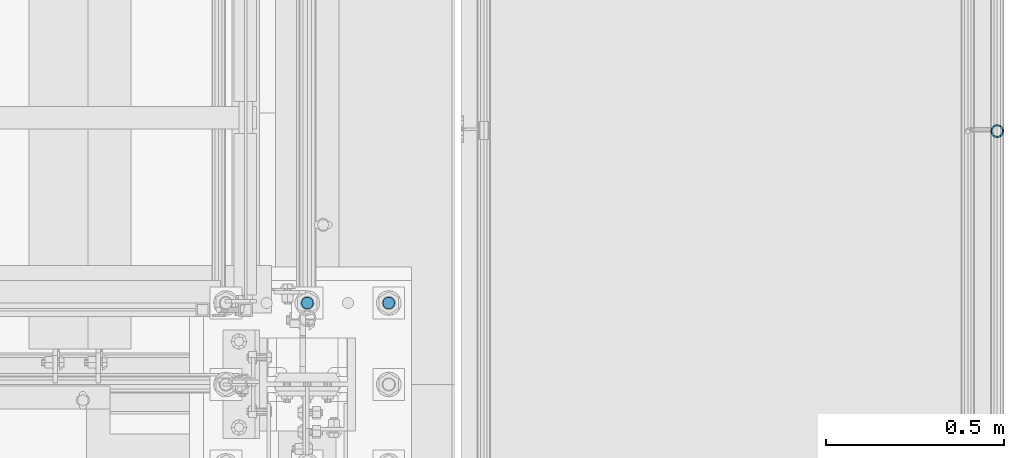
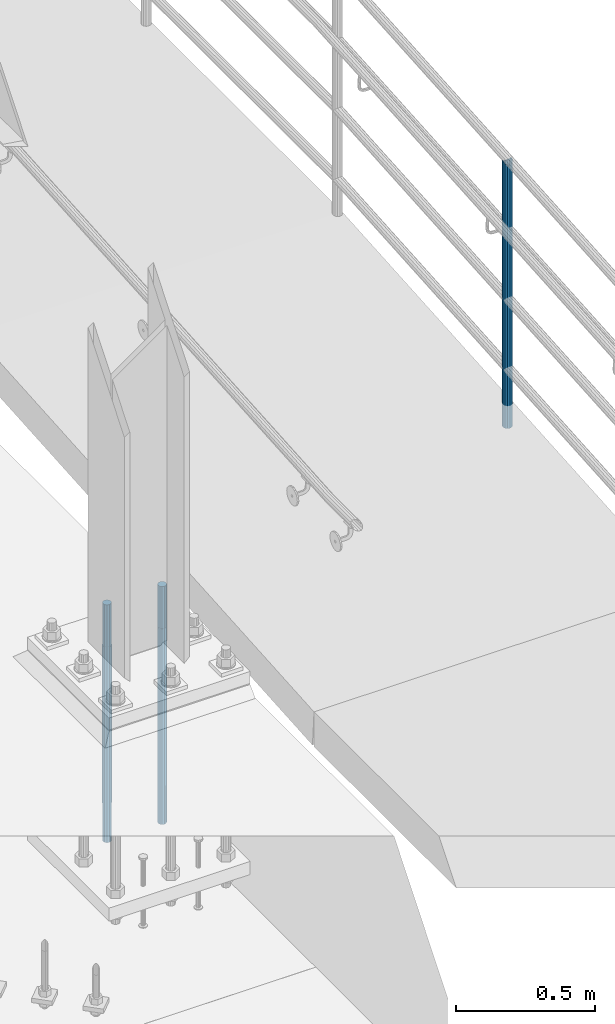
# One storey, part 658 of 1876: 3 columns, 2 elements without a shape of their own.
"""IFC2X3 building model written with IfcOpenShell, lengths in millimetres."""

import ifcopenshell
import ifcopenshell.guid

model = None  # the IFC model being written
_history = None  # IfcOwnerHistory: only IFC2X3 demands one
_inside = {}  # id of a spatial element -> (the spatial element, [elements in it])
_under = {}  # id of a project, library or spatial element -> (it, [spatial elements below it])
_declared = {}  # id of a project -> (the project, [libraries it declares])
_typed = {}  # id of a type object -> (the type object, [elements of that type])
_made_of = {}  # id of a material, layer set ... -> (it, [elements and type objects made of it])


def new_model(schema):
    """Start an empty IFC model of exactly this schema.

    Asked for "IFC4X3", IfcOpenShell would pick the latest addendum, in which some entities
    have other attributes; the version numbers below select the first issue.
    IFC2X3 requires an IfcOwnerHistory on every rooted entity: one is made here for all.
    """
    global model, _history
    if schema == "IFC4X3":
        model = ifcopenshell.file(schema_version=(4, 3, 0, 0))
    else:
        model = ifcopenshell.file(schema=schema)
    _inside.clear()
    _under.clear()
    _declared.clear()
    _typed.clear()
    _made_of.clear()
    _history = None
    if model.schema == "IFC2X3":
        org = make("IfcOrganization", Name="unknown")
        user = make(
            "IfcPersonAndOrganization",
            ThePerson=make("IfcPerson", FamilyName="unknown"),
            TheOrganization=org,
        )
        app = make(
            "IfcApplication",
            ApplicationDeveloper=org,
            Version="unknown",
            ApplicationFullName="unknown",
            ApplicationIdentifier="unknown",
        )
        _history = make(
            "IfcOwnerHistory",
            OwningUser=user,
            OwningApplication=app,
            ChangeAction="ADDED",
            CreationDate=0,
        )
    return model


def make(cls, **values):
    """One entity of the class cls with the attributes given. An attribute that is None is left unset."""
    return model.create_entity(
        cls, **{name: value for name, value in values.items() if value is not None}
    )


def rooted(cls, **values):
    """An entity with a GlobalId (a new one), such as an element, a storey or a relation."""
    return make(cls, GlobalId=ifcopenshell.guid.new(), OwnerHistory=_history, **values)


def si_unit(unit_type, name, prefix=None):
    """IfcSIUnit, for example si_unit("LENGTHUNIT", "METRE", prefix="MILLI")."""
    return make("IfcSIUnit", UnitType=unit_type, Prefix=prefix, Name=name)


def assignment(units):
    """IfcUnitAssignment: the units of a project."""
    return None if units is None else make("IfcUnitAssignment", Units=units)


def point(xyz):
    """IfcCartesianPoint."""
    return None if xyz is None else make("IfcCartesianPoint", Coordinates=xyz)


def direction(xyz):
    """IfcDirection."""
    return None if xyz is None else make("IfcDirection", DirectionRatios=xyz)


def frame(location, z_axis=None, x_axis=None):
    """IfcAxis2Placement3D, a coordinate frame: its origin and axes. An axis left out is left unset."""
    return make(
        "IfcAxis2Placement3D",
        Location=point(location),
        Axis=direction(z_axis),
        RefDirection=direction(x_axis),
    )


def origin_with_axes():
    """The frame at (0, 0, 0) with the z axis (0, 0, 1) and the x axis (1, 0, 0) written out."""
    return frame((0.0, 0.0, 0.0), z_axis=(0.0, 0.0, 1.0), x_axis=(1.0, 0.0, 0.0))


def place(relative_to, where):
    """IfcLocalPlacement: puts the frame where relative to a parent placement (None: the world)."""
    return make(
        "IfcLocalPlacement", PlacementRelTo=relative_to, RelativePlacement=where
    )


def context(
    kind, dimensions, precision=None, world=None, true_north=None, identifier=None
):
    """IfcGeometricRepresentationContext, for example the 3D "Model" context."""
    return make(
        "IfcGeometricRepresentationContext",
        ContextIdentifier=identifier,
        ContextType=kind,
        CoordinateSpaceDimension=dimensions,
        Precision=precision,
        WorldCoordinateSystem=world,
        TrueNorth=true_north,
    )


def subcontext(parent, identifier, kind, view, scale=None):
    """IfcGeometricRepresentationSubContext, for example "Body" below "Model"."""
    return make(
        "IfcGeometricRepresentationSubContext",
        ContextIdentifier=identifier,
        ContextType=kind,
        ParentContext=parent,
        TargetScale=scale,
        TargetView=view,
    )


def project(units=None, contexts=None):
    """IfcProject with its units and contexts."""
    return rooted(
        "IfcProject",
        Name="project",
        RepresentationContexts=contexts,
        UnitsInContext=assignment(units),
    )


def spatial(cls, under=None, at=None, **own):
    """A site, building, storey or space (cls), placed at a placement, below another one or the project."""
    s = rooted(cls, ObjectPlacement=at, **own)
    if under is not None:
        _under.setdefault(under.id(), (under, []))[1].append(s)
    return s


def faces_of(points, faces, orient=None, outer=None):
    """IfcFace entities. A face is a list of loops; a loop is a list of indices into points, from 0.

    orient and outer hold one flag for each loop. By default every Orientation is true, the
    first loop of a face is its IfcFaceOuterBound and the others are IfcFaceBound.
    """
    made = []
    for i, loops in enumerate(faces):
        bounds = []
        for j, loop in enumerate(loops):
            is_outer = j == 0 if outer is None else outer[i][j]
            bounds.append(
                make(
                    "IfcFaceOuterBound" if is_outer else "IfcFaceBound",
                    Bound=make("IfcPolyLoop", Polygon=[points[k] for k in loop]),
                    Orientation=True if orient is None else orient[i][j],
                )
            )
        made.append(make("IfcFace", Bounds=bounds))
    return made


def faceted_brep(points, faces, orient=None, outer=None, voids=None):
    """IfcFacetedBrep: a solid bounded by flat faces; with voids (closed shells), ...WithVoids."""
    shared = [point(p) for p in points]
    hull = make("IfcClosedShell", CfsFaces=faces_of(shared, faces, orient, outer))
    if voids is None:
        return make("IfcFacetedBrep", Outer=hull)
    return make(
        "IfcFacetedBrepWithVoids",
        Outer=hull,
        Voids=[
            make(cls, CfsFaces=faces_of(shared, fs, o, b)) for cls, fs, o, b in voids
        ],
    )


def shape(context_of_items, identifier, shape_type, items):
    """IfcShapeRepresentation: the items that make up one representation, for example the "Body"."""
    return make(
        "IfcShapeRepresentation",
        ContextOfItems=context_of_items,
        RepresentationIdentifier=identifier,
        RepresentationType=shape_type,
        Items=items,
    )


def material(Name=None, Category=None):
    """IfcMaterial."""
    return make("IfcMaterial", Name=Name, Category=Category)


def made_of(thing, what):
    """Note that an element or type object is made of a material, layer set ...; save() writes the relation."""
    if what is not None:
        _made_of.setdefault(what.id(), (what, []))[1].append(thing)
    return thing


def type_object(cls, material=None, **own):
    """A type object (cls), such as IfcWallType, which elements share."""
    return made_of(rooted(cls, **own), material)


def element(
    cls,
    number,
    at=None,
    inside=None,
    cuts=None,
    type_object=None,
    material=None,
    context=None,
    identifier="Body",
    shape_type=None,
    held_by="IfcProductDefinitionShape",
    body=None,
    shapes=None,
    **own,
):
    """One element of the class cls, such as IfcWall. Its Tag is "e" and its number.

    at: its placement. inside: the storey or other place that contains it. cuts: it is an
    opening in that element (IfcRelVoidsElement). A single representation is given by context,
    identifier, shape_type and body (its items); several are given by shapes. held_by: the class
    of the entity that holds the representations. save() writes the other relations.
    """
    e = rooted(cls, Tag="e%d" % number, ObjectPlacement=at, **own)
    if body is not None:
        shapes = [shape(context, identifier, shape_type, body)]
    if shapes is not None:
        e.Representation = make(held_by, Representations=shapes)
    if inside is not None:
        _inside.setdefault(inside.id(), (inside, []))[1].append(e)
    if cuts is not None:
        rooted(
            "IfcRelVoidsElement", RelatingBuildingElement=cuts, RelatedOpeningElement=e
        )
    if type_object is not None:
        _typed.setdefault(type_object.id(), (type_object, []))[1].append(e)
    return made_of(e, material)


def aggregate(whole, parts):
    """IfcRelAggregates: a whole, such as a stair, and the parts it consists of."""
    return rooted("IfcRelAggregates", RelatingObject=whole, RelatedObjects=parts)


def save(model, path):
    """Write the relations noted so far, then the file.

    IfcRelAggregates (storeys below a building ...), IfcRelContainedInSpatialStructure (elements
    in a storey), IfcRelDefinesByType, IfcRelAssociatesMaterial and IfcRelDeclares: one each for
    every whole, place, type object, material and project.
    """
    for whole, parts in _under.values():
        aggregate(whole, parts)
    for where, things in _inside.values():
        rooted(
            "IfcRelContainedInSpatialStructure",
            RelatedElements=things,
            RelatingStructure=where,
        )
    for kind, things in _typed.values():
        rooted("IfcRelDefinesByType", RelatedObjects=things, RelatingType=kind)
    for what, things in _made_of.values():
        rooted("IfcRelAssociatesMaterial", RelatedObjects=things, RelatingMaterial=what)
    for by, libraries in _declared.values():
        rooted("IfcRelDeclares", RelatingContext=by, RelatedDefinitions=libraries)
    model.write(path)


model = new_model("IFC2X3")

# Units and contexts
model_context = context("Model", 3, precision=1e-05, world=origin_with_axes())
body_context = subcontext(model_context, "Body", "Model", "MODEL_VIEW")
ifc_project = project(units=[si_unit("LENGTHUNIT", "METRE", prefix="MILLI"), si_unit("AREAUNIT", "SQUARE_METRE"), si_unit("VOLUMEUNIT", "CUBIC_METRE"), si_unit("MASSUNIT", "GRAM", prefix="KILO"), si_unit("TIMEUNIT", "SECOND"), si_unit("PLANEANGLEUNIT", "RADIAN"), si_unit("SOLIDANGLEUNIT", "STERADIAN"), si_unit("THERMODYNAMICTEMPERATUREUNIT", "DEGREE_CELSIUS"), si_unit("LUMINOUSINTENSITYUNIT", "LUMEN")], contexts=[model_context])

# Site, building, storey
site_placement = place(None, origin_with_axes())
site = spatial("IfcSite", under=ifc_project, at=site_placement, CompositionType="ELEMENT")
building_placement = place(site_placement, origin_with_axes())
building = spatial("IfcBuilding", under=site, at=building_placement, Name="Undefined", CompositionType="ELEMENT")
storey_placement = place(building_placement, origin_with_axes())
storey = spatial("IfcBuildingStorey", under=building, at=storey_placement, Name="Undefined", CompositionType="ELEMENT", Elevation=0.0)

# Assembly, column
assembly_1_placement = place(storey_placement, origin_with_axes())
assembly_1 = element("IfcElementAssembly", 1, at=assembly_1_placement, inside=storey, Name="RAIL", AssemblyPlace="NOTDEFINED", PredefinedType="RIGID_FRAME")
ifc_material_1 = material()
column_type_1 = type_object("IfcColumnType", PredefinedType="NOTDEFINED")
column_1_placement = place(assembly_1_placement, frame((9556.7501953125, -6400.8, -12.6999949132689), z_axis=(0.0, 1.0, 0.0), x_axis=(0.0, 0.0, 1.0)))
column_1 = element("IfcColumn", 2, at=column_1_placement, type_object=column_type_1, material=ifc_material_1, Name="POST", context=body_context, shape_type="Brep", body=[
    faceted_brep([(1153.06137959604, -9.52499999999964, 16.4977839420935), (1152.58700590502, -9.52499999999964, 9.99208795656978), (1152.12089074517, -7.14374999999927, 12.3733379565701), (1150.34122112338, 0.0, 14.2875000000004), (1150.68848676698, 0.0, 19.0500000000002), (1152.12089074517, 7.14374999999927, 12.3733379565701), (1152.58700590502, 9.52499999999964, 9.99208795656978), (1153.06137959604, 9.52499999999964, 16.4977839420935), (1168.40000000408, 19.0499999999993, 0.0), (1159.54424336595, 16.4977839420935, 9.52499999999964), (1158.15518079154, 16.4977839420935, -9.52499999999964), (1155.23521458271, 12.373337956571, 7.14375000000018), (1156.63356006224, 14.2875000000004, 0.0), (1154.1934176519, 12.373337956571, -7.14375000000018), (1151.12982633329, 9.52499999999964, -9.99208795656978), (1150.65545264226, 9.52499999999964, -16.4977839420935), (1150.31644552984, 7.14374999999927, -12.3733379565701), (1148.25762726176, 0.0, -14.2875000000004), (1147.91036161815, 0.0, -19.0500000000002), (1151.12982633329, -9.52499999999964, -9.99208795656978), (1150.65545264226, -9.52499999999964, -16.4977839420935), (1150.31644552984, -7.14374999999927, -12.3733379565701), (1168.40000000408, -19.0499999999993, 0.0), (1158.15518079154, -16.4977839420935, -9.52499999999964), (1159.54424336595, -16.4977839420935, 9.52499999999964), (1154.1934176519, -12.373337956571, -7.14375000000018), (1156.63356006224, -14.2875000000004, 0.0), (1155.23521458271, -12.373337956571, 7.14375000000018), (0.0, -16.4977839420935, -9.52500000000146), (0.0, -9.52500000000009, -16.4977839420935), (0.0, 0.0, -19.05), (0.0, 9.52500000000009, -16.4977839420935), (0.0, 16.4977839420935, -9.52500000000146), (-9.09494701772928e-13, 19.05, -1.81898940354586e-12), (0.0, 16.4977839420935, 9.52500000000146), (0.0, 9.52500000000009, 16.4977839420935), (0.0, 0.0, 19.0499999999993), (0.0, -9.52500000000009, 16.4977839420935), (0.0, -16.4977839420935, 9.52500000000146), (0.0, -19.0500000000002, 0.0), (0.0, -12.373337956571, -7.14375000000018), (0.0, -7.14374999999927, -12.3733379565701), (0.0, 0.0, -14.2874999999999), (0.0, 7.14374999999927, -12.3733379565701), (0.0, 12.373337956571, -7.14375000000018), (0.0, 14.2875000000004, 0.0), (0.0, 12.373337956571, 7.14375000000018), (0.0, 7.14374999999927, 12.3733379565701), (0.0, 0.0, 14.2874999999999), (0.0, -7.14374999999927, 12.3733379565701), (0.0, -12.373337956571, 7.14375000000018), (0.0, -14.2875000000004, 0.0)], [[[0, 1, 2, 3, 4]], [[4, 3, 5, 6, 7]], [[8, 9, 10]], [[7, 6, 11, 12, 13, 14, 15, 10, 9]], [[16, 17, 18, 15, 14]], [[19, 20, 18, 17, 21]], [[22, 23, 24]], [[24, 23, 20, 19, 25, 26, 27, 1, 0]], [[28, 29, 20, 23]], [[29, 30, 18, 20]], [[30, 31, 15, 18]], [[31, 32, 10, 15]], [[32, 33, 8, 10]], [[33, 34, 9, 8]], [[34, 35, 7, 9]], [[35, 36, 4, 7]], [[36, 37, 0, 4]], [[37, 38, 24, 0]], [[38, 39, 22, 24]], [[39, 28, 23, 22]], [[38, 37, 36, 35, 34, 33, 32, 31, 30, 29, 28, 39], [40, 41, 42, 43, 44, 45, 46, 47, 48, 49, 50, 51]], [[40, 51, 26, 25]], [[21, 41, 40, 25, 19]], [[42, 41, 21, 17]], [[43, 42, 17, 16]], [[44, 43, 16, 14, 13]], [[45, 44, 13, 12]], [[46, 45, 12, 11]], [[5, 47, 46, 11, 6]], [[48, 47, 5, 3]], [[49, 48, 3, 2]], [[50, 49, 2, 1, 27]], [[51, 50, 27, 26]]]),
])
aggregate(assembly_1, [column_1])

# Assembly, columns
assembly_2_placement = place(storey_placement, origin_with_axes())
assembly_2 = element("IfcElementAssembly", 3, at=assembly_2_placement, inside=storey, Name="TEMPLATE", AssemblyPlace="NOTDEFINED", PredefinedType="RIGID_FRAME")
ifc_material_2 = material(Name="STEEL/F1554-GR.105")
column_type_2 = type_object("IfcColumnType", PredefinedType="NOTDEFINED")
column_2_placement = place(assembly_2_placement, frame((7848.6, -6883.4, 0.0), z_axis=(-1.0, 0.0, 0.0), x_axis=(0.0, 0.0, -1.0)))
column_2 = element("IfcColumn", 4, at=column_2_placement, type_object=column_type_2, material=ifc_material_2, Name="ANCHOR_BOLTS", context=body_context, shape_type="Brep", body=[
    faceted_brep([(-184.15, -14.2894191624437, 8.25), (-184.15, -8.25, 14.2894191624432), (-184.15, 0.0, 16.5), (-184.15, 8.25, 14.2894191624432), (-184.15, 14.2894191624437, 8.25), (-184.15, 16.5, 0.0), (-184.15, 14.2894191624437, -8.25), (-184.15, 8.25, -14.2894191624432), (-184.15, 0.0, -16.5), (-184.15, -8.25, -14.2894191624432), (-184.15, -14.2894191624437, -8.25), (-184.15, -16.5, 0.0), (0.0, 16.5, 0.0), (0.0, 14.2894191624437, -8.25), (0.0, 8.25, -14.2894191624432), (0.0, 0.0, -16.5), (0.0, -8.25, -14.2894191624432), (0.0, -14.2894191624437, -8.25), (0.0, -16.5, 0.0), (0.0, -14.2894191624437, 8.25), (0.0, -8.25, 14.2894191624432), (0.0, 0.0, 16.5), (0.0, 8.25, 14.2894191624432), (0.0, 14.2894191624437, 8.25), (0.0, -15.1229686135858, 8.73125000000073), (0.0, -8.73124999999999, 15.1229686135848), (0.0, 0.0, 17.4625000000015), (0.0, 8.73124999999999, 15.1229686135848), (0.0, 15.1229686135858, 8.73125000000073), (0.0, 17.4625, 0.0), (0.0, 15.1229686135858, -8.73125000000073), (0.0, 8.73124999999999, -15.1229686135848), (0.0, 0.0, -17.4625000000015), (0.0, -8.73124999999999, -15.1229686135848), (0.0, -15.1229686135857, -8.73125000000073), (0.0, -17.4625, 0.0), (692.15, -17.4624999999996, 0.0), (692.15, -15.1229686135857, 8.73124999999982), (692.15, -8.73124999999982, 15.1229686135857), (692.15, 0.0, 17.4624999999996), (692.15, 8.73124999999982, 15.1229686135857), (692.15, 15.1229686135857, 8.73124999999982), (692.15, 17.4624999999996, 0.0), (692.15, 15.1229686135857, -8.73124999999982), (692.15, 8.73124999999982, -15.1229686135857), (692.15, 0.0, -17.4624999999996), (692.15, -8.73124999999982, -15.1229686135857), (692.15, -15.1229686135857, -8.73124999999982), (692.15, -8.25, 14.2894191624437), (692.15, 0.0, 16.5), (692.15, 8.25, 14.2894191624437), (692.15, 14.2894191624437, 8.25), (692.15, 16.5, 0.0), (692.15, 14.2894191624437, -8.25), (692.15, 8.25, -14.2894191624437), (692.15, 0.0, -16.5), (692.15, -8.25, -14.2894191624437), (692.15, -14.2894191624437, -8.25), (692.15, -16.5, 0.0), (692.15, -14.2894191624437, 8.25), (857.25, -8.25, -14.2894191624437), (857.25, 0.0, -16.5), (857.25, 8.25, -14.2894191624437), (857.25, 14.2894191624437, -8.25), (857.25, 16.5, 0.0), (857.25, 14.2894191624437, 8.25), (857.25, 8.25, 14.2894191624437), (857.25, 0.0, 16.5), (857.25, -8.25, 14.2894191624437), (857.25, -14.2894191624437, 8.25), (857.25, -16.5, 0.0), (857.25, -14.2894191624437, -8.25)], [[[0, 1, 2, 3, 4, 5, 6, 7, 8, 9, 10, 11]], [[6, 5, 12, 13]], [[7, 6, 13, 14]], [[8, 7, 14, 15]], [[9, 8, 15, 16]], [[10, 9, 16, 17]], [[11, 10, 17, 18]], [[0, 11, 18, 19]], [[1, 0, 19, 20]], [[2, 1, 20, 21]], [[3, 2, 21, 22]], [[4, 3, 22, 23]], [[5, 4, 23, 12]], [[24, 25, 26, 27, 28, 29, 30, 31, 32, 33, 34, 35], [22, 21, 20, 19, 18, 17, 16, 15, 14, 13, 12, 23]], [[24, 35, 36, 37]], [[25, 24, 37, 38]], [[26, 25, 38, 39]], [[27, 26, 39, 40]], [[28, 27, 40, 41]], [[29, 28, 41, 42]], [[30, 29, 42, 43]], [[31, 30, 43, 44]], [[32, 31, 44, 45]], [[33, 32, 45, 46]], [[34, 33, 46, 47]], [[35, 34, 47, 36]], [[46, 45, 44, 43, 42, 41, 40, 39, 38, 37, 36, 47], [48, 49, 50, 51, 52, 53, 54, 55, 56, 57, 58, 59]], [[60, 61, 62, 63, 64, 65, 66, 67, 68, 69, 70, 71]], [[68, 67, 49, 48]], [[69, 68, 48, 59]], [[70, 69, 59, 58]], [[71, 70, 58, 57]], [[60, 71, 57, 56]], [[61, 60, 56, 55]], [[62, 61, 55, 54]], [[63, 62, 54, 53]], [[64, 63, 53, 52]], [[65, 64, 52, 51]], [[66, 65, 51, 50]], [[67, 66, 50, 49]]]),
])
column_3_placement = place(assembly_2_placement, frame((7620.0, -6883.4, 0.0), z_axis=(-1.0, 0.0, 0.0), x_axis=(0.0, 0.0, -1.0)))
column_3 = element("IfcColumn", 5, at=column_3_placement, type_object=column_type_2, material=ifc_material_2, Name="ANCHOR_BOLTS", context=body_context, shape_type="Brep", body=[
    faceted_brep([(-184.15, -14.2894191624437, 8.25), (-184.15, -8.25, 14.2894191624432), (-184.15, 0.0, 16.5), (-184.15, 8.25, 14.2894191624432), (-184.15, 14.2894191624437, 8.25), (-184.15, 16.5, 0.0), (-184.15, 14.2894191624437, -8.25), (-184.15, 8.25, -14.2894191624432), (-184.15, 0.0, -16.5), (-184.15, -8.25, -14.2894191624432), (-184.15, -14.2894191624437, -8.25), (-184.15, -16.5, 0.0), (0.0, 16.5, 0.0), (0.0, 14.2894191624437, -8.25), (0.0, 8.25, -14.2894191624432), (0.0, 0.0, -16.5), (0.0, -8.25, -14.2894191624432), (0.0, -14.2894191624437, -8.25), (0.0, -16.5, 0.0), (0.0, -14.2894191624437, 8.25), (0.0, -8.25, 14.2894191624432), (0.0, 0.0, 16.5), (0.0, 8.25, 14.2894191624432), (0.0, 14.2894191624437, 8.25), (0.0, -15.1229686135858, 8.73125000000073), (0.0, -8.73124999999999, 15.1229686135848), (0.0, 0.0, 17.4625000000015), (0.0, 8.73124999999999, 15.1229686135848), (0.0, 15.1229686135858, 8.73125000000073), (0.0, 17.4625, 0.0), (0.0, 15.1229686135858, -8.73125000000073), (0.0, 8.73124999999999, -15.1229686135848), (0.0, 0.0, -17.4625000000015), (0.0, -8.73124999999999, -15.1229686135848), (0.0, -15.1229686135857, -8.73125000000073), (0.0, -17.4625, 0.0), (692.15, -17.4624999999996, 0.0), (692.15, -15.1229686135857, 8.73124999999982), (692.15, -8.73124999999982, 15.1229686135857), (692.15, 0.0, 17.4624999999996), (692.15, 8.73124999999982, 15.1229686135857), (692.15, 15.1229686135857, 8.73124999999982), (692.15, 17.4624999999996, 0.0), (692.15, 15.1229686135857, -8.73124999999982), (692.15, 8.73124999999982, -15.1229686135857), (692.15, 0.0, -17.4624999999996), (692.15, -8.73124999999982, -15.1229686135857), (692.15, -15.1229686135857, -8.73124999999982), (692.15, -8.25, 14.2894191624437), (692.15, 0.0, 16.5), (692.15, 8.25, 14.2894191624437), (692.15, 14.2894191624437, 8.25), (692.15, 16.5, 0.0), (692.15, 14.2894191624437, -8.25), (692.15, 8.25, -14.2894191624437), (692.15, 0.0, -16.5), (692.15, -8.25, -14.2894191624437), (692.15, -14.2894191624437, -8.25), (692.15, -16.5, 0.0), (692.15, -14.2894191624437, 8.25), (857.25, -8.25, -14.2894191624437), (857.25, 0.0, -16.5), (857.25, 8.25, -14.2894191624437), (857.25, 14.2894191624437, -8.25), (857.25, 16.5, 0.0), (857.25, 14.2894191624437, 8.25), (857.25, 8.25, 14.2894191624437), (857.25, 0.0, 16.5), (857.25, -8.25, 14.2894191624437), (857.25, -14.2894191624437, 8.25), (857.25, -16.5, 0.0), (857.25, -14.2894191624437, -8.25)], [[[0, 1, 2, 3, 4, 5, 6, 7, 8, 9, 10, 11]], [[6, 5, 12, 13]], [[7, 6, 13, 14]], [[8, 7, 14, 15]], [[9, 8, 15, 16]], [[10, 9, 16, 17]], [[11, 10, 17, 18]], [[0, 11, 18, 19]], [[1, 0, 19, 20]], [[2, 1, 20, 21]], [[3, 2, 21, 22]], [[4, 3, 22, 23]], [[5, 4, 23, 12]], [[24, 25, 26, 27, 28, 29, 30, 31, 32, 33, 34, 35], [22, 21, 20, 19, 18, 17, 16, 15, 14, 13, 12, 23]], [[24, 35, 36, 37]], [[25, 24, 37, 38]], [[26, 25, 38, 39]], [[27, 26, 39, 40]], [[28, 27, 40, 41]], [[29, 28, 41, 42]], [[30, 29, 42, 43]], [[31, 30, 43, 44]], [[32, 31, 44, 45]], [[33, 32, 45, 46]], [[34, 33, 46, 47]], [[35, 34, 47, 36]], [[46, 45, 44, 43, 42, 41, 40, 39, 38, 37, 36, 47], [48, 49, 50, 51, 52, 53, 54, 55, 56, 57, 58, 59]], [[60, 61, 62, 63, 64, 65, 66, 67, 68, 69, 70, 71]], [[68, 67, 49, 48]], [[69, 68, 48, 59]], [[70, 69, 59, 58]], [[71, 70, 58, 57]], [[60, 71, 57, 56]], [[61, 60, 56, 55]], [[62, 61, 55, 54]], [[63, 62, 54, 53]], [[64, 63, 53, 52]], [[65, 64, 52, 51]], [[66, 65, 51, 50]], [[67, 66, 50, 49]]]),
])
aggregate(assembly_2, [column_2, column_3])

save(model, "model.ifc")
